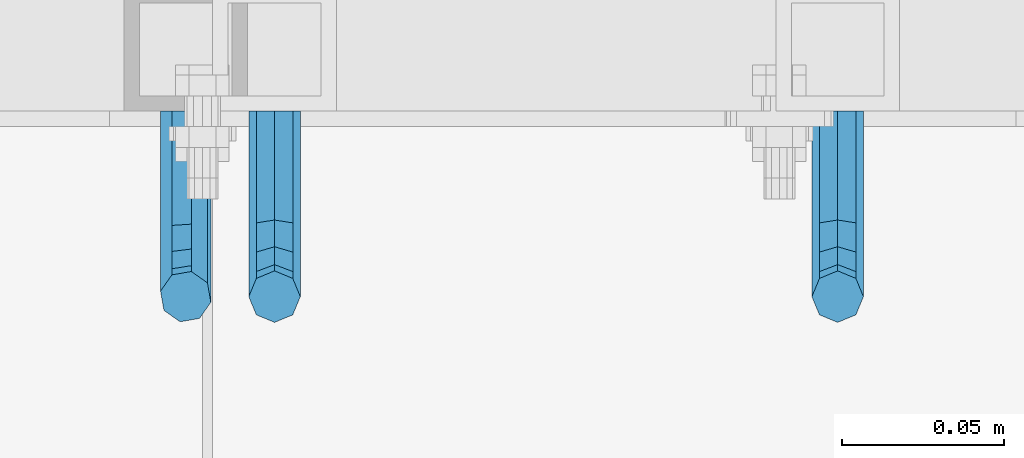
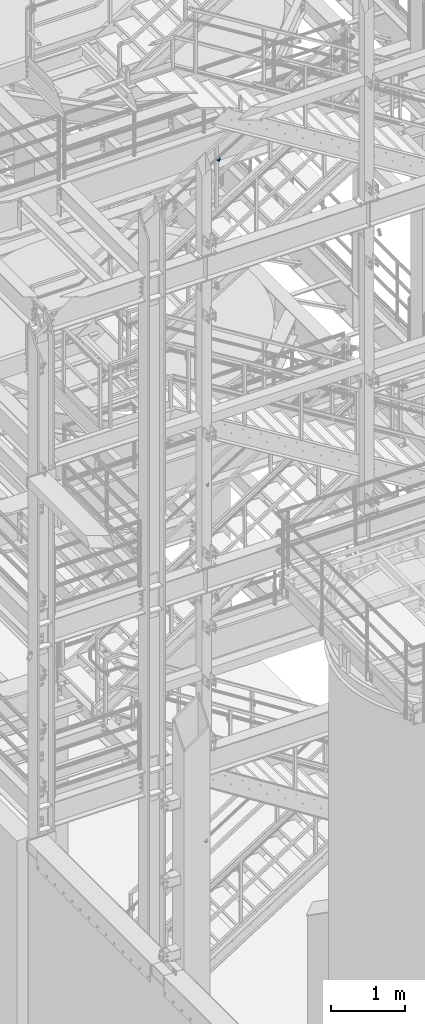
# One storey, part 1190 of 1876: 3 beams, 3 elements without a shape of their own.
"""IFC2X3 building model written with IfcOpenShell, lengths in millimetres."""

import ifcopenshell
import ifcopenshell.guid

model = None  # the IFC model being written
_history = None  # IfcOwnerHistory: only IFC2X3 demands one
_inside = {}  # id of a spatial element -> (the spatial element, [elements in it])
_under = {}  # id of a project, library or spatial element -> (it, [spatial elements below it])
_declared = {}  # id of a project -> (the project, [libraries it declares])
_typed = {}  # id of a type object -> (the type object, [elements of that type])
_made_of = {}  # id of a material, layer set ... -> (it, [elements and type objects made of it])


def new_model(schema):
    """Start an empty IFC model of exactly this schema.

    Asked for "IFC4X3", IfcOpenShell would pick the latest addendum, in which some entities
    have other attributes; the version numbers below select the first issue.
    IFC2X3 requires an IfcOwnerHistory on every rooted entity: one is made here for all.
    """
    global model, _history
    if schema == "IFC4X3":
        model = ifcopenshell.file(schema_version=(4, 3, 0, 0))
    else:
        model = ifcopenshell.file(schema=schema)
    _inside.clear()
    _under.clear()
    _declared.clear()
    _typed.clear()
    _made_of.clear()
    _history = None
    if model.schema == "IFC2X3":
        org = make("IfcOrganization", Name="unknown")
        user = make(
            "IfcPersonAndOrganization",
            ThePerson=make("IfcPerson", FamilyName="unknown"),
            TheOrganization=org,
        )
        app = make(
            "IfcApplication",
            ApplicationDeveloper=org,
            Version="unknown",
            ApplicationFullName="unknown",
            ApplicationIdentifier="unknown",
        )
        _history = make(
            "IfcOwnerHistory",
            OwningUser=user,
            OwningApplication=app,
            ChangeAction="ADDED",
            CreationDate=0,
        )
    return model


def make(cls, **values):
    """One entity of the class cls with the attributes given. An attribute that is None is left unset."""
    return model.create_entity(
        cls, **{name: value for name, value in values.items() if value is not None}
    )


def rooted(cls, **values):
    """An entity with a GlobalId (a new one), such as an element, a storey or a relation."""
    return make(cls, GlobalId=ifcopenshell.guid.new(), OwnerHistory=_history, **values)


def si_unit(unit_type, name, prefix=None):
    """IfcSIUnit, for example si_unit("LENGTHUNIT", "METRE", prefix="MILLI")."""
    return make("IfcSIUnit", UnitType=unit_type, Prefix=prefix, Name=name)


def assignment(units):
    """IfcUnitAssignment: the units of a project."""
    return None if units is None else make("IfcUnitAssignment", Units=units)


def point(xyz):
    """IfcCartesianPoint."""
    return None if xyz is None else make("IfcCartesianPoint", Coordinates=xyz)


def direction(xyz):
    """IfcDirection."""
    return None if xyz is None else make("IfcDirection", DirectionRatios=xyz)


def frame(location, z_axis=None, x_axis=None):
    """IfcAxis2Placement3D, a coordinate frame: its origin and axes. An axis left out is left unset."""
    return make(
        "IfcAxis2Placement3D",
        Location=point(location),
        Axis=direction(z_axis),
        RefDirection=direction(x_axis),
    )


def origin_with_axes():
    """The frame at (0, 0, 0) with the z axis (0, 0, 1) and the x axis (1, 0, 0) written out."""
    return frame((0.0, 0.0, 0.0), z_axis=(0.0, 0.0, 1.0), x_axis=(1.0, 0.0, 0.0))


def place(relative_to, where):
    """IfcLocalPlacement: puts the frame where relative to a parent placement (None: the world)."""
    return make(
        "IfcLocalPlacement", PlacementRelTo=relative_to, RelativePlacement=where
    )


def context(
    kind, dimensions, precision=None, world=None, true_north=None, identifier=None
):
    """IfcGeometricRepresentationContext, for example the 3D "Model" context."""
    return make(
        "IfcGeometricRepresentationContext",
        ContextIdentifier=identifier,
        ContextType=kind,
        CoordinateSpaceDimension=dimensions,
        Precision=precision,
        WorldCoordinateSystem=world,
        TrueNorth=true_north,
    )


def subcontext(parent, identifier, kind, view, scale=None):
    """IfcGeometricRepresentationSubContext, for example "Body" below "Model"."""
    return make(
        "IfcGeometricRepresentationSubContext",
        ContextIdentifier=identifier,
        ContextType=kind,
        ParentContext=parent,
        TargetScale=scale,
        TargetView=view,
    )


def project(units=None, contexts=None):
    """IfcProject with its units and contexts."""
    return rooted(
        "IfcProject",
        Name="project",
        RepresentationContexts=contexts,
        UnitsInContext=assignment(units),
    )


def spatial(cls, under=None, at=None, **own):
    """A site, building, storey or space (cls), placed at a placement, below another one or the project."""
    s = rooted(cls, ObjectPlacement=at, **own)
    if under is not None:
        _under.setdefault(under.id(), (under, []))[1].append(s)
    return s


def faces_of(points, faces, orient=None, outer=None):
    """IfcFace entities. A face is a list of loops; a loop is a list of indices into points, from 0.

    orient and outer hold one flag for each loop. By default every Orientation is true, the
    first loop of a face is its IfcFaceOuterBound and the others are IfcFaceBound.
    """
    made = []
    for i, loops in enumerate(faces):
        bounds = []
        for j, loop in enumerate(loops):
            is_outer = j == 0 if outer is None else outer[i][j]
            bounds.append(
                make(
                    "IfcFaceOuterBound" if is_outer else "IfcFaceBound",
                    Bound=make("IfcPolyLoop", Polygon=[points[k] for k in loop]),
                    Orientation=True if orient is None else orient[i][j],
                )
            )
        made.append(make("IfcFace", Bounds=bounds))
    return made


def faceted_brep(points, faces, orient=None, outer=None, voids=None):
    """IfcFacetedBrep: a solid bounded by flat faces; with voids (closed shells), ...WithVoids."""
    shared = [point(p) for p in points]
    hull = make("IfcClosedShell", CfsFaces=faces_of(shared, faces, orient, outer))
    if voids is None:
        return make("IfcFacetedBrep", Outer=hull)
    return make(
        "IfcFacetedBrepWithVoids",
        Outer=hull,
        Voids=[
            make(cls, CfsFaces=faces_of(shared, fs, o, b)) for cls, fs, o, b in voids
        ],
    )


def shape(context_of_items, identifier, shape_type, items):
    """IfcShapeRepresentation: the items that make up one representation, for example the "Body"."""
    return make(
        "IfcShapeRepresentation",
        ContextOfItems=context_of_items,
        RepresentationIdentifier=identifier,
        RepresentationType=shape_type,
        Items=items,
    )


def material(Name=None, Category=None):
    """IfcMaterial."""
    return make("IfcMaterial", Name=Name, Category=Category)


def made_of(thing, what):
    """Note that an element or type object is made of a material, layer set ...; save() writes the relation."""
    if what is not None:
        _made_of.setdefault(what.id(), (what, []))[1].append(thing)
    return thing


def type_object(cls, material=None, **own):
    """A type object (cls), such as IfcWallType, which elements share."""
    return made_of(rooted(cls, **own), material)


def element(
    cls,
    number,
    at=None,
    inside=None,
    cuts=None,
    type_object=None,
    material=None,
    context=None,
    identifier="Body",
    shape_type=None,
    held_by="IfcProductDefinitionShape",
    body=None,
    shapes=None,
    **own,
):
    """One element of the class cls, such as IfcWall. Its Tag is "e" and its number.

    at: its placement. inside: the storey or other place that contains it. cuts: it is an
    opening in that element (IfcRelVoidsElement). A single representation is given by context,
    identifier, shape_type and body (its items); several are given by shapes. held_by: the class
    of the entity that holds the representations. save() writes the other relations.
    """
    e = rooted(cls, Tag="e%d" % number, ObjectPlacement=at, **own)
    if body is not None:
        shapes = [shape(context, identifier, shape_type, body)]
    if shapes is not None:
        e.Representation = make(held_by, Representations=shapes)
    if inside is not None:
        _inside.setdefault(inside.id(), (inside, []))[1].append(e)
    if cuts is not None:
        rooted(
            "IfcRelVoidsElement", RelatingBuildingElement=cuts, RelatedOpeningElement=e
        )
    if type_object is not None:
        _typed.setdefault(type_object.id(), (type_object, []))[1].append(e)
    return made_of(e, material)


def aggregate(whole, parts):
    """IfcRelAggregates: a whole, such as a stair, and the parts it consists of."""
    return rooted("IfcRelAggregates", RelatingObject=whole, RelatedObjects=parts)


def save(model, path):
    """Write the relations noted so far, then the file.

    IfcRelAggregates (storeys below a building ...), IfcRelContainedInSpatialStructure (elements
    in a storey), IfcRelDefinesByType, IfcRelAssociatesMaterial and IfcRelDeclares: one each for
    every whole, place, type object, material and project.
    """
    for whole, parts in _under.values():
        aggregate(whole, parts)
    for where, things in _inside.values():
        rooted(
            "IfcRelContainedInSpatialStructure",
            RelatedElements=things,
            RelatingStructure=where,
        )
    for kind, things in _typed.values():
        rooted("IfcRelDefinesByType", RelatedObjects=things, RelatingType=kind)
    for what, things in _made_of.values():
        rooted("IfcRelAssociatesMaterial", RelatedObjects=things, RelatingMaterial=what)
    for by, libraries in _declared.values():
        rooted("IfcRelDeclares", RelatingContext=by, RelatedDefinitions=libraries)
    model.write(path)


model = new_model("IFC2X3")

# Units and contexts
model_context = context("Model", 3, precision=1e-05, world=origin_with_axes())
body_context = subcontext(model_context, "Body", "Model", "MODEL_VIEW")
ifc_project = project(units=[si_unit("LENGTHUNIT", "METRE", prefix="MILLI"), si_unit("AREAUNIT", "SQUARE_METRE"), si_unit("VOLUMEUNIT", "CUBIC_METRE"), si_unit("MASSUNIT", "GRAM", prefix="KILO"), si_unit("TIMEUNIT", "SECOND"), si_unit("PLANEANGLEUNIT", "RADIAN"), si_unit("SOLIDANGLEUNIT", "STERADIAN"), si_unit("THERMODYNAMICTEMPERATUREUNIT", "DEGREE_CELSIUS"), si_unit("LUMINOUSINTENSITYUNIT", "LUMEN")], contexts=[model_context])

# Site, building, storey
site_placement = place(None, origin_with_axes())
site = spatial("IfcSite", under=ifc_project, at=site_placement, CompositionType="ELEMENT")
building_placement = place(site_placement, origin_with_axes())
building = spatial("IfcBuilding", under=site, at=building_placement, Name="Undefined", CompositionType="ELEMENT")
storey_placement = place(building_placement, origin_with_axes())
storey = spatial("IfcBuildingStorey", under=building, at=storey_placement, Name="Undefined", CompositionType="ELEMENT", Elevation=0.0)

# Assembly, beam
assembly_1_placement = place(storey_placement, origin_with_axes())
assembly_1 = element("IfcElementAssembly", 1, at=assembly_1_placement, inside=storey, Name="RAIL", AssemblyPlace="NOTDEFINED", PredefinedType="RIGID_FRAME")
ifc_material = material(Name="STEEL/A36")
beam_type = type_object("IfcBeamType", PredefinedType="NOTDEFINED")
beam_1_placement = place(assembly_1_placement, frame((4085.16666677088, -4800.59999885446, 12907.6577970441), z_axis=(1.0, 0.0, 0.0), x_axis=(0.0, -1.0, 0.0)))
beam_1 = element("IfcBeam", 2, at=beam_1_placement, type_object=beam_type, material=ifc_material, Name="BRACKET", context=body_context, shape_type="Brep", body=[
    faceted_brep([(0.0, -5.61266007566822, 5.61266007566883), (0.0, 0.0, 7.9375), (0.0, 5.61266007566822, 5.61266007566883), (0.0, 7.9375, 0.0), (0.0, 5.61266007566822, -5.61266007566883), (0.0, 0.0, -7.9375), (0.0, -5.61266007566822, -5.61266007566883), (0.0, -7.9375, 0.0), (23.8125, 5.61266007566883, 5.61266007566792), (23.8125, 7.9375, 0.0), (23.8125, 5.61266007566883, -5.61266007566792), (23.8125, 0.0, -7.9375), (23.8125, -5.61266007566883, -5.61266007566792), (23.8125, -7.9375, 0.0), (23.8125, -5.61266007566883, 5.61266007566792), (23.8125, 0.0, 7.9375), (36.5702095103989, -2.53766620105534, 7.9375), (38.7180815328547, 2.64775556579752, 5.61266007566792), (39.6077592547972, 4.79562758825296, 0.0), (38.7180815328547, 2.64775556579752, -5.61266007566792), (36.5702095103989, -2.53766620105534, -7.9375), (34.4223374879439, -7.72308796790867, -5.61266007566792), (33.5326597660014, -9.87095999036364, 0.0), (34.4223374879439, -7.72308796790867, 5.61266007566792), (43.4169233967659, -13.733078129113, 5.61266007566792), (47.385673396765, -9.76432812911298, 7.9375), (41.7730133210971, -15.3769882047809, 0.0), (43.4169233967659, -13.733078129113, -5.61266007566792), (47.385673396765, -9.76432812911298, -7.9375), (51.354423396765, -5.79557812911253, -5.61266007566792), (52.9983334724338, -4.15166805344461, 0.0), (51.354423396765, -5.79557812911253, 5.61266007566792), (54.6123353248231, -20.5797920154787, 7.9375), (59.7977570916764, -18.4319199930233, 5.61266007566792), (49.4269135579698, -22.7276640379341, 5.61266007566792), (47.2790415355148, -23.6173417598766, 0.0), (49.4269135579698, -22.7276640379341, -5.61266007566792), (54.6123353248231, -20.5797920154787, -7.9375), (59.7977570916764, -18.4319199930233, -5.61266007566792), (61.9456291141314, -17.5422422710808, 0.0), (62.7626616015468, -33.3375015258789, 5.61266007566792), (65.0875015258789, -33.3375015258789, 0.0), (57.1500015258789, -33.3375015258789, 7.9375), (51.5373414502101, -33.3375015258789, 5.61266007566792), (49.2125015258789, -33.3375015258789, 0.0), (51.5373414502101, -33.3375015258789, -5.61266007566792), (57.1500015258789, -33.3375015258789, -7.9375), (62.7626616015468, -33.3375015258789, -5.61266007566792), (65.0875015258789, -66.5341532333514, 2.45290721068159e-09), (62.7626616015805, -63.0815171359536, -5.61266007334871), (57.1500015259289, -61.6513884384531, -7.93749999776537), (51.5373414502437, -63.0815171359118, -5.6126600734151), (49.2125015258789, -66.5341532333259, 2.41197994910181e-09), (51.5373414501864, -69.9867893307037, 5.61266007818085), (57.1500015258471, -71.4169180281988, 7.93750000258842), (62.7626616015223, -69.9867893307346, 5.61266007822906)], [[[0, 1, 2, 3, 4, 5, 6, 7]], [[3, 2, 8, 9]], [[4, 3, 9, 10]], [[5, 4, 10, 11]], [[6, 5, 11, 12]], [[7, 6, 12, 13]], [[0, 7, 13, 14]], [[1, 0, 14, 15]], [[2, 1, 15, 8]], [[8, 15, 16, 17]], [[9, 8, 17, 18]], [[10, 9, 18, 19]], [[11, 10, 19, 20]], [[12, 11, 20, 21]], [[13, 12, 21, 22]], [[14, 13, 22, 23]], [[15, 14, 23, 16]], [[23, 24, 25, 16]], [[22, 26, 24, 23]], [[21, 27, 26, 22]], [[20, 28, 27, 21]], [[19, 29, 28, 20]], [[18, 30, 29, 19]], [[17, 31, 30, 18]], [[16, 25, 31, 17]], [[25, 32, 33, 31]], [[24, 34, 32, 25]], [[26, 35, 34, 24]], [[27, 36, 35, 26]], [[28, 37, 36, 27]], [[29, 38, 37, 28]], [[30, 39, 38, 29]], [[31, 33, 39, 30]], [[33, 40, 41, 39]], [[32, 42, 40, 33]], [[34, 43, 42, 32]], [[35, 44, 43, 34]], [[36, 45, 44, 35]], [[37, 46, 45, 36]], [[38, 47, 46, 37]], [[39, 41, 47, 38]], [[47, 41, 48, 49]], [[46, 47, 49, 50]], [[45, 46, 50, 51]], [[44, 45, 51, 52]], [[43, 44, 52, 53]], [[42, 43, 53, 54]], [[40, 42, 54, 55]], [[41, 40, 55, 48]], [[54, 53, 52, 51, 50, 49, 48, 55]]]),
])
aggregate(assembly_1, [beam_1])

assembly_2_placement = place(storey_placement, origin_with_axes())
assembly_2 = element("IfcElementAssembly", 3, at=assembly_2_placement, inside=storey, Name="RAIL", AssemblyPlace="NOTDEFINED", PredefinedType="RIGID_FRAME")
beam_2_placement = place(assembly_2_placement, frame((3911.59999717497, -4800.59999885446, 7598.35225360931), z_axis=(1.0, 0.0, 0.0), x_axis=(0.0, -1.0, 0.0)))
beam_2 = element("IfcBeam", 4, at=beam_2_placement, type_object=beam_type, material=ifc_material, Name="BRACKET", context=body_context, shape_type="Brep", body=[
    faceted_brep([(0.0, -5.61266007566822, 5.61266007566883), (0.0, 0.0, 7.9375), (0.0, 5.61266007566822, 5.61266007566883), (0.0, 7.9375, 0.0), (0.0, 5.61266007566822, -5.61266007566883), (0.0, 0.0, -7.9375), (0.0, -5.61266007566822, -5.61266007566883), (0.0, -7.9375, 0.0), (23.8125, 5.61266007566883, 5.61266007566792), (23.8125, 7.9375, 0.0), (23.8125, 5.61266007566883, -5.61266007566792), (23.8125, 0.0, -7.9375), (23.8125, -5.61266007566883, -5.61266007566792), (23.8125, -7.9375, 0.0), (23.8125, -5.61266007566883, 5.61266007566792), (23.8125, 0.0, 7.9375), (36.5702095103989, -2.53766620105534, 7.9375), (38.7180815328547, 2.64775556579752, 5.61266007566792), (39.6077592547972, 4.79562758825296, 0.0), (38.7180815328547, 2.64775556579752, -5.61266007566792), (36.5702095103989, -2.53766620105534, -7.9375), (34.4223374879439, -7.72308796790867, -5.61266007566792), (33.5326597660014, -9.87095999036364, 0.0), (34.4223374879439, -7.72308796790867, 5.61266007566792), (43.4169233967659, -13.733078129113, 5.61266007566792), (47.385673396765, -9.76432812911298, 7.9375), (41.7730133210971, -15.3769882047809, 0.0), (43.4169233967659, -13.733078129113, -5.61266007566792), (47.385673396765, -9.76432812911298, -7.9375), (51.354423396765, -5.79557812911253, -5.61266007566792), (52.9983334724338, -4.15166805344461, 0.0), (51.354423396765, -5.79557812911253, 5.61266007566792), (54.6123353248231, -20.5797920154787, 7.9375), (59.7977570916764, -18.4319199930233, 5.61266007566792), (49.4269135579698, -22.7276640379341, 5.61266007566792), (47.2790415355148, -23.6173417598766, 0.0), (49.4269135579698, -22.7276640379341, -5.61266007566792), (54.6123353248231, -20.5797920154787, -7.9375), (59.7977570916764, -18.4319199930233, -5.61266007566792), (61.9456291141314, -17.5422422710808, 0.0), (62.7626616015468, -33.3375015258789, 5.61266007566792), (65.0875015258789, -33.3375015258789, 0.0), (57.1500015258789, -33.3375015258789, 7.9375), (51.5373414502101, -33.3375015258789, 5.61266007566792), (49.2125015258789, -33.3375015258789, 0.0), (51.5373414502101, -33.3375015258789, -5.61266007566792), (57.1500015258789, -33.3375015258789, -7.9375), (62.7626616015468, -33.3375015258789, -5.61266007566792), (65.0875015258789, -66.3198535804604, 0.0), (62.7626616015468, -62.7481608643047, -5.61266007566792), (57.1500015258789, -61.2687173006434, -7.9375), (51.537341450211, -62.7481608643047, -5.61266007566792), (49.2125015258789, -66.3198535804604, 0.0), (51.537341450211, -69.8915462966161, 5.61266007566792), (57.1500015258789, -71.3709898602756, 7.9375), (62.7626616015468, -69.8915462966161, 5.61266007566792)], [[[0, 1, 2, 3, 4, 5, 6, 7]], [[3, 2, 8, 9]], [[4, 3, 9, 10]], [[5, 4, 10, 11]], [[6, 5, 11, 12]], [[7, 6, 12, 13]], [[0, 7, 13, 14]], [[1, 0, 14, 15]], [[2, 1, 15, 8]], [[8, 15, 16, 17]], [[9, 8, 17, 18]], [[10, 9, 18, 19]], [[11, 10, 19, 20]], [[12, 11, 20, 21]], [[13, 12, 21, 22]], [[14, 13, 22, 23]], [[15, 14, 23, 16]], [[23, 24, 25, 16]], [[22, 26, 24, 23]], [[21, 27, 26, 22]], [[20, 28, 27, 21]], [[19, 29, 28, 20]], [[18, 30, 29, 19]], [[17, 31, 30, 18]], [[16, 25, 31, 17]], [[25, 32, 33, 31]], [[24, 34, 32, 25]], [[26, 35, 34, 24]], [[27, 36, 35, 26]], [[28, 37, 36, 27]], [[29, 38, 37, 28]], [[30, 39, 38, 29]], [[31, 33, 39, 30]], [[33, 40, 41, 39]], [[32, 42, 40, 33]], [[34, 43, 42, 32]], [[35, 44, 43, 34]], [[36, 45, 44, 35]], [[37, 46, 45, 36]], [[38, 47, 46, 37]], [[39, 41, 47, 38]], [[47, 41, 48, 49]], [[46, 47, 49, 50]], [[45, 46, 50, 51]], [[44, 45, 51, 52]], [[43, 44, 52, 53]], [[42, 43, 53, 54]], [[40, 42, 54, 55]], [[41, 40, 55, 48]], [[54, 53, 52, 51, 50, 49, 48, 55]]]),
])
aggregate(assembly_2, [beam_2])

assembly_3_placement = place(storey_placement, origin_with_axes())
assembly_3 = element("IfcElementAssembly", 5, at=assembly_3_placement, inside=storey, Name="RAIL", AssemblyPlace="NOTDEFINED", PredefinedType="RIGID_FRAME")
beam_3_placement = place(assembly_3_placement, frame((3884.21562501342, -4800.59999885446, 1726.6179456377), z_axis=(0.844410015326383, 0.0, 0.535697420207059), x_axis=(0.0, -1.0, 0.0)))
beam_3 = element("IfcBeam", 6, at=beam_3_placement, type_object=beam_type, material=ifc_material, Name="BRACKET", context=body_context, shape_type="Brep", body=[
    faceted_brep([(0.0, -5.61266007566822, 5.61266007566883), (0.0, 0.0, 7.9375), (0.0, 5.61266007566822, 5.61266007566883), (0.0, 7.9375, 0.0), (0.0, 5.61266007566822, -5.61266007566883), (0.0, 0.0, -7.9375), (0.0, -5.61266007566822, -5.61266007566883), (0.0, -7.9375, 0.0), (25.7500019073486, 7.93750000000102, 9.09494701772928e-13), (25.7500019073486, 5.61266007566837, -5.61266007566837), (25.7500019073486, -6.82121026329696e-13, -7.93750000000091), (25.7500019073486, -5.6126600756694, -5.61266007566974), (25.7500019073486, -7.93750000000102, -1.81898940354586e-12), (25.7500019073486, -5.61266007566837, 5.61266007566746), (25.7500019073486, 6.82121026329696e-13, 7.93750000000045), (25.7500019073486, 5.6126600756694, 5.61266007566928), (38.4293366836664, 3.48299342205155, 6.96372994876174), (40.3311989638523, 5.48838972025123, 1.55372631168893), (40.7305556863994, 3.09647240503659, -4.01637957277262), (39.3934690994565, -2.29160580041184, -6.48369522136136), (37.103186391596, -7.51958175847221, -4.40290058978781), (35.20132411141, -9.5249780566719, 1.00710304728545), (34.8019673888657, -7.13306074145851, 6.57720893174746), (36.1390539758049, -1.74498253600871, 9.04452458033529), (44.9464670438292, -6.71427237123442, 12.1970638641865), (49.1783576787429, -2.58178409626339, 10.8112514273389), (42.4758531820917, -11.4627955199268, 9.32401168030583), (43.2137681863505, -14.0457330830792, 3.87508987960746), (46.7279514549882, -12.95003526696, -0.957797047369695), (50.9598420899019, -8.81754699198905, -2.34360948421772), (53.4304559516395, -4.06902384329646, 0.529442699663377), (52.6925409473806, -1.48608628014392, 5.97836450036175), (56.3606238862012, -11.6583650794599, 16.5694742441578), (60.952125596792, -11.9241272539106, 12.6003035112408), (50.8313923112155, -14.1513401749901, 16.9151723234295), (47.6033797389591, -17.942701540198, 13.4348925027043), (48.5675121547501, -20.8115211072019, 8.16733550011031), (53.159013865341, -21.0772832816523, 4.19816476719325), (58.6882454403267, -18.5843081861219, 3.85246668792206), (61.916258012584, -14.7929468209162, 7.33274650864814), (63.8525060225302, -24.2366360838653, 20.4114131579445), (64.8960754294303, -27.4426764670732, 15.3577905213597), (58.8827003833576, -22.3649223522546, 23.3617611737764), (52.8979032529824, -22.9239597913389, 22.4805607149005), (49.4039276223266, -25.5862718511769, 18.2840070589591), (50.4474970292276, -28.7923122343848, 13.2303844223738), (55.4173026683993, -30.6640259659952, 10.2800364065429), (61.4020997987745, -30.104988526911, 11.1612368654173), (64.8960754294312, -56.018050113816, 33.4861329926521), (61.4020997987755, -56.0180500190148, 27.6005968197555), (55.4173026684002, -56.018049999108, 26.364740543037), (50.4474970292276, -56.0180500657575, 30.5025120082541), (49.4039276223266, -56.01805017992, 37.5900608090838), (52.8979032529824, -56.0180502747214, 43.4755969819798), (58.8827003833576, -56.018050294628, 44.7114532586984), (63.8525060225302, -56.018050227979, 40.5736817934817)], [[[0, 1, 2, 3, 4, 5, 6, 7]], [[4, 3, 8, 9]], [[5, 4, 9, 10]], [[6, 5, 10, 11]], [[7, 6, 11, 12]], [[0, 7, 12, 13]], [[1, 0, 13, 14]], [[2, 1, 14, 15]], [[3, 2, 15, 8]], [[8, 15, 16, 17]], [[9, 8, 17, 18]], [[10, 9, 18, 19]], [[11, 10, 19, 20]], [[12, 11, 20, 21]], [[13, 12, 21, 22]], [[14, 13, 22, 23]], [[15, 14, 23, 16]], [[23, 24, 25, 16]], [[22, 26, 24, 23]], [[21, 27, 26, 22]], [[20, 28, 27, 21]], [[19, 29, 28, 20]], [[18, 30, 29, 19]], [[17, 31, 30, 18]], [[16, 25, 31, 17]], [[25, 32, 33, 31]], [[24, 34, 32, 25]], [[26, 35, 34, 24]], [[27, 36, 35, 26]], [[28, 37, 36, 27]], [[29, 38, 37, 28]], [[30, 39, 38, 29]], [[31, 33, 39, 30]], [[33, 40, 41, 39]], [[32, 42, 40, 33]], [[34, 43, 42, 32]], [[35, 44, 43, 34]], [[36, 45, 44, 35]], [[37, 46, 45, 36]], [[38, 47, 46, 37]], [[39, 41, 47, 38]], [[47, 41, 48, 49]], [[46, 47, 49, 50]], [[45, 46, 50, 51]], [[44, 45, 51, 52]], [[43, 44, 52, 53]], [[42, 43, 53, 54]], [[40, 42, 54, 55]], [[41, 40, 55, 48]], [[54, 53, 52, 51, 50, 49, 48, 55]]]),
])
aggregate(assembly_3, [beam_3])

save(model, "model.ifc")
